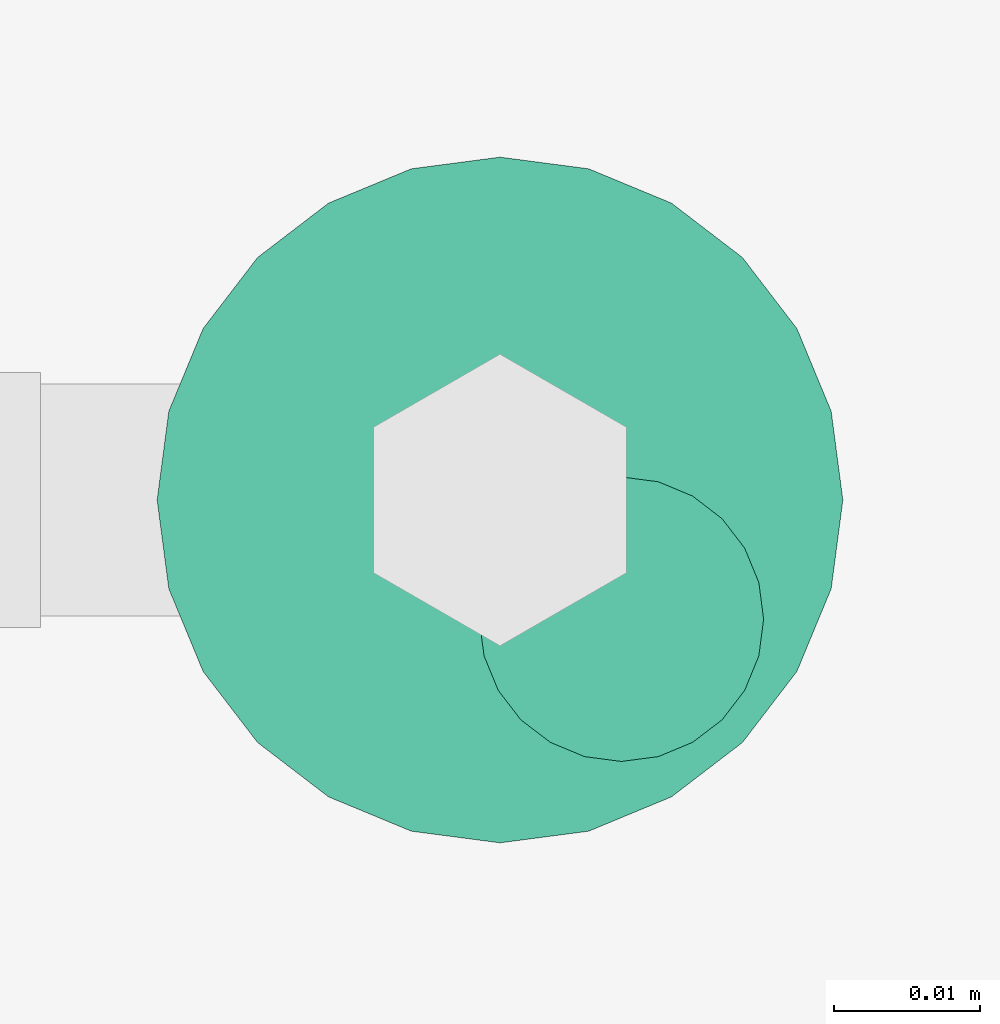
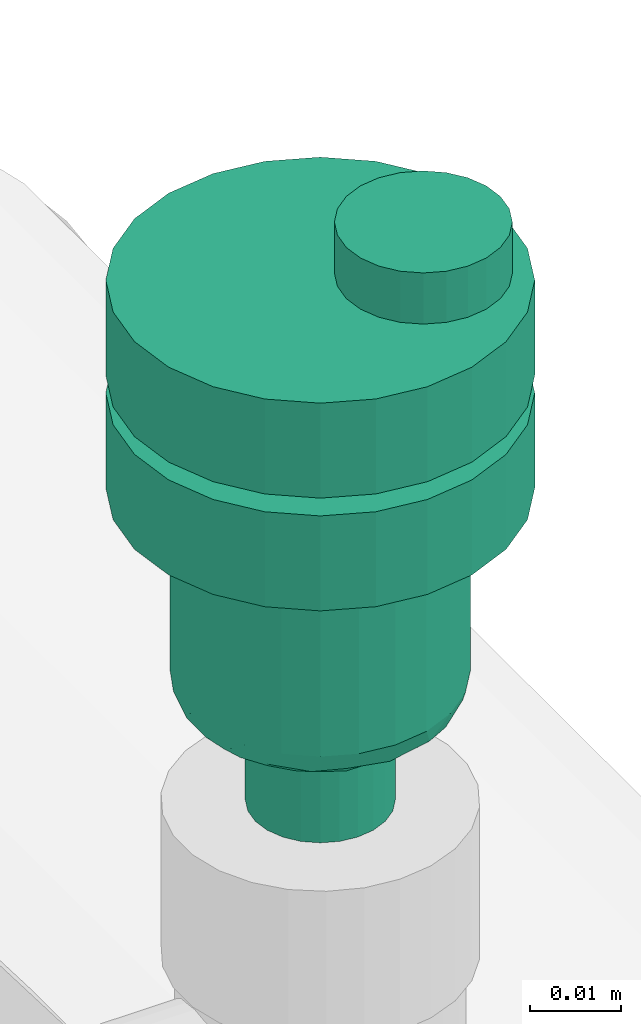
# One storey, part 596 of 827: 1 flow controller.
"""IFC2X3 building model written with IfcOpenShell, lengths in millimetres."""

from ifc_helpers import new_model, entity, si_unit, converted_unit, derived_unit, direction, frame, origin, place, context, subcontext, project, spatial, faceted_brep, source, transform, mapped, material, type_object, type_shapes, element, save


model = new_model("IFC2X3")

# Units and contexts
model_context = context("Model", 3, precision=0.01, world=origin(), true_north=direction((6.12303176911189e-17, 1.0)))
body_context = subcontext(model_context, "Body", "Model", "MODEL_VIEW")
ifc_project = project(units=[si_unit("LENGTHUNIT", "METRE", prefix="MILLI"), si_unit("AREAUNIT", "SQUARE_METRE"), si_unit("VOLUMEUNIT", "CUBIC_METRE"), converted_unit("PLANEANGLEUNIT", "DEGREE", entity("IfcRatioMeasure", 0.0174532925199433), si_unit("PLANEANGLEUNIT", "RADIAN"), dimensions=[0, 0, 0, 0, 0, 0, 0]), si_unit("MASSUNIT", "GRAM", prefix="KILO"), derived_unit("MASSDENSITYUNIT", [(si_unit("MASSUNIT", "GRAM", prefix="KILO"), 1), (si_unit("LENGTHUNIT", "METRE"), -3)]), derived_unit("MOMENTOFINERTIAUNIT", [(si_unit("LENGTHUNIT", "METRE"), 4)]), si_unit("TIMEUNIT", "SECOND"), si_unit("FREQUENCYUNIT", "HERTZ"), si_unit("THERMODYNAMICTEMPERATUREUNIT", "DEGREE_CELSIUS"), derived_unit("THERMALTRANSMITTANCEUNIT", [(si_unit("MASSUNIT", "GRAM", prefix="KILO"), 1), (si_unit("THERMODYNAMICTEMPERATUREUNIT", "KELVIN"), -1), (si_unit("TIMEUNIT", "SECOND"), -3)]), derived_unit("VOLUMETRICFLOWRATEUNIT", [(si_unit("LENGTHUNIT", "METRE"), 3), (si_unit("TIMEUNIT", "SECOND"), -1)]), derived_unit("MASSFLOWRATEUNIT", [(si_unit("MASSUNIT", "GRAM", prefix="KILO"), 1), (si_unit("TIMEUNIT", "SECOND"), -1)]), derived_unit("ROTATIONALFREQUENCYUNIT", [(si_unit("TIMEUNIT", "SECOND"), -1)]), si_unit("ELECTRICCURRENTUNIT", "AMPERE"), si_unit("ELECTRICVOLTAGEUNIT", "VOLT"), si_unit("POWERUNIT", "WATT"), si_unit("FORCEUNIT", "NEWTON", prefix="KILO"), si_unit("ILLUMINANCEUNIT", "LUX"), si_unit("LUMINOUSFLUXUNIT", "LUMEN"), si_unit("LUMINOUSINTENSITYUNIT", "CANDELA"), derived_unit("USERDEFINED", [(si_unit("MASSUNIT", "GRAM", prefix="KILO"), -1), (si_unit("LENGTHUNIT", "METRE"), -2), (si_unit("TIMEUNIT", "SECOND"), 3), (si_unit("LUMINOUSFLUXUNIT", "LUMEN"), 1)]), derived_unit("LINEARVELOCITYUNIT", [(si_unit("LENGTHUNIT", "METRE"), 1), (si_unit("TIMEUNIT", "SECOND"), -1)]), si_unit("PRESSUREUNIT", "PASCAL"), derived_unit("USERDEFINED", [(si_unit("LENGTHUNIT", "METRE"), -2), (si_unit("MASSUNIT", "GRAM", prefix="KILO"), 1), (si_unit("TIMEUNIT", "SECOND"), -2)]), derived_unit("LINEARFORCEUNIT", [(si_unit("MASSUNIT", "GRAM", prefix="KILO"), 1), (si_unit("LENGTHUNIT", "METRE"), 1), (si_unit("TIMEUNIT", "SECOND"), -2), (si_unit("LENGTHUNIT", "METRE"), -1)]), derived_unit("PLANARFORCEUNIT", [(si_unit("MASSUNIT", "GRAM", prefix="KILO"), 1), (si_unit("LENGTHUNIT", "METRE"), 1), (si_unit("TIMEUNIT", "SECOND"), -2), (si_unit("LENGTHUNIT", "METRE"), -2)])], contexts=[model_context])

# Site, building, storey
site_placement = place(None, origin())
site = spatial("IfcSite", under=ifc_project, at=site_placement, CompositionType="ELEMENT")
building_placement = place(site_placement, origin())
building = spatial("IfcBuilding", under=site, at=building_placement, CompositionType="ELEMENT")
storey_placement = place(building_placement, frame((0.0, 0.0, 28200.0)))
storey = spatial("IfcBuildingStorey", under=building, at=storey_placement, Name="08", CompositionType="ELEMENT", Elevation=28200.0)

# Flow controller
ifc_material = material()
valve_type = type_object("IfcValveType", PredefinedType="NOTDEFINED", material=ifc_material)
shared_shape = source(origin(), body_context, "Body", "Brep", [
    faceted_brep([(-6.86, -13.27, -15.58), (-5.66, -12.77, -15.58), (-5.66, -12.77, -13.2), (-6.86, -13.27, -13.2), (-6.86, -13.27, -0.5), (-5.66, -12.77, -0.5), (-5.66, -12.77, 2.49), (-6.86, -13.27, 2.49), (-8.16, -13.44, -15.58), (-8.16, -13.44, -13.2), (-8.16, -13.44, -0.5), (-8.16, -13.44, 2.49), (-3.83, -10.94, -15.58), (-3.33, -9.74, -15.58), (-3.33, -9.74, -13.2), (-3.83, -10.94, -13.2), (-3.83, -10.94, -0.5), (-3.33, -9.74, -0.5), (-3.33, -9.74, 2.49), (-3.83, -10.94, 2.49), (-4.62, -11.98, -15.58), (-4.62, -11.98, -13.2), (-4.62, -11.98, -0.5), (-4.62, -11.98, 2.49), (-3.16, -8.44, -13.2), (-3.16, -8.44, -15.58), (-3.16, -8.44, 2.49), (-3.16, -8.44, -0.5), (-3.83, -5.94, -15.58), (-4.62, -4.91, -15.58), (-4.62, -4.91, -13.2), (-3.83, -5.94, -13.2), (-3.83, -5.94, -0.5), (-4.62, -4.91, -0.5), (-4.62, -4.91, 2.49), (-3.83, -5.94, 2.49), (-3.33, -7.15, -15.58), (-3.33, -7.15, -13.2), (-3.33, -7.15, -0.5), (-3.33, -7.15, 2.49), (-6.86, -3.61, -15.58), (-8.16, -3.44, -15.58), (-8.16, -3.44, -13.2), (-6.86, -3.61, -13.2), (-6.86, -3.61, -0.5), (-8.16, -3.44, -0.5), (-8.16, -3.44, 2.49), (-6.86, -3.61, 2.49), (-5.66, -4.11, -15.58), (-5.66, -4.11, -13.2), (-5.66, -4.11, -0.5), (-5.66, -4.11, 2.49), (-9.45, -3.61, -0.5), (-9.45, -3.61, 2.49), (-9.45, -3.61, -15.58), (-9.45, -3.61, -13.2), (-10.66, -4.11, -0.5), (-10.66, -4.11, 2.49), (-10.66, -4.11, -15.58), (-10.66, -4.11, -13.2), (-12.49, -5.94, 2.49), (-11.69, -4.91, 2.49), (-11.69, -4.91, -0.5), (-12.49, -5.94, -0.5), (-11.69, -4.91, -15.58), (-12.49, -5.94, -15.58), (-12.49, -5.94, -13.2), (-11.69, -4.91, -13.2), (-12.99, -7.15, 2.49), (-12.99, -7.15, -0.5), (-12.99, -7.15, -15.58), (-12.99, -7.15, -13.2), (-13.16, -8.44, 2.49), (-13.16, -8.44, -0.5), (-13.16, -8.44, -13.2), (-13.16, -8.44, -15.58), (-12.49, -10.94, -0.5), (-12.49, -10.94, 2.49), (-12.99, -9.74, 2.49), (-12.99, -9.74, -0.5), (-12.99, -9.74, -15.58), (-12.49, -10.94, -15.58), (-12.49, -10.94, -13.2), (-12.99, -9.74, -13.2), (-11.69, -11.98, -0.5), (-11.69, -11.98, 2.49), (-11.69, -11.98, -15.58), (-11.69, -11.98, -13.2), (-9.45, -13.27, 2.49), (-10.66, -12.77, 2.49), (-10.66, -12.77, -0.5), (-9.45, -13.27, -0.5), (-10.66, -12.77, -15.58), (-9.45, -13.27, -15.58), (-9.45, -13.27, -13.2), (-10.66, -12.77, -13.2), (6.08, -22.7, -0.5), (0.0, -23.5, -0.5), (11.75, -20.35, -0.5), (16.62, -16.62, -0.5), (20.35, -11.75, -0.5), (22.7, -6.08, -0.5), (23.5, 0.0, -0.5), (22.7, 6.08, -0.5), (20.35, 11.75, -0.5), (16.62, 16.62, -0.5), (11.75, 20.35, -0.5), (6.08, 22.7, -0.5), (0.0, 23.5, -0.5), (-6.08, 22.7, -0.5), (-11.75, 20.35, -0.5), (-16.62, 16.62, -0.5), (-20.35, 11.75, -0.5), (-22.7, 6.08, -0.5), (-23.5, 0.0, -0.5), (-22.7, -6.08, -0.5), (-20.35, -11.75, -0.5), (-16.62, -16.62, -0.5), (-11.75, -20.35, -0.5), (-6.08, -22.7, -0.5), (11.75, 20.35, -13.2), (6.08, 22.7, -13.2), (16.62, 16.62, -13.2), (20.35, 11.75, -13.2), (22.7, 6.08, -13.2), (23.5, 0.0, -13.2), (22.7, -6.08, -13.2), (20.35, -11.75, -13.2), (16.62, -16.62, -13.2), (11.75, -20.35, -13.2), (6.08, -22.7, -13.2), (0.0, -23.5, -13.2), (-6.08, -22.7, -13.2), (-11.75, -20.35, -13.2), (-16.62, -16.62, -13.2), (-20.35, -11.75, -13.2), (-22.7, -6.08, -13.2), (-23.5, 0.0, -13.2), (-22.7, 6.08, -13.2), (-20.35, 11.75, -13.2), (-16.62, 16.62, -13.2), (-11.75, 20.35, -13.2), (-6.08, 22.7, -13.2), (0.0, 23.5, -13.2), (-22.7, -6.08, -28.28), (-22.7, -6.08, -15.58), (-23.5, 0.0, -15.58), (-23.5, 0.0, -28.28), (-20.35, -11.75, -28.28), (-20.35, -11.75, -15.58), (-11.75, -20.35, -15.58), (-16.62, -16.62, -15.58), (-16.62, -16.62, -28.28), (-11.75, -20.35, -28.28), (-6.08, -22.7, -15.58), (-6.08, -22.7, -28.28), (0.0, -23.5, -15.58), (0.0, -23.5, -28.28), (6.08, -22.7, -28.28), (6.08, -22.7, -15.58), (11.75, -20.35, -28.28), (11.75, -20.35, -15.58), (20.35, -11.75, -15.58), (16.62, -16.62, -15.58), (16.62, -16.62, -28.28), (20.35, -11.75, -28.28), (22.7, -6.08, -15.58), (22.7, -6.08, -28.28), (23.5, 0.0, -15.58), (23.5, 0.0, -28.28), (22.7, 6.08, -28.28), (22.7, 6.08, -15.58), (20.35, 11.75, -28.28), (20.35, 11.75, -15.58), (11.75, 20.35, -15.58), (16.62, 16.62, -15.58), (16.62, 16.62, -28.28), (11.75, 20.35, -28.28), (6.08, 22.7, -15.58), (6.08, 22.7, -28.28), (0.0, 23.5, -15.58), (0.0, 23.5, -28.28), (-6.08, 22.7, -28.28), (-6.08, 22.7, -15.58), (-11.75, 20.35, -28.28), (-11.75, 20.35, -15.58), (-20.35, 11.75, -15.58), (-16.62, 16.62, -15.58), (-16.62, 16.62, -28.28), (-20.35, 11.75, -28.28), (-22.7, 6.08, -15.58), (-22.7, 6.08, -28.28), (8.23, 14.25, -28.28), (4.26, 15.89, -28.28), (11.63, 11.63, -28.28), (14.25, 8.22, -28.28), (15.89, 4.26, -28.28), (16.45, 0.0, -28.28), (15.89, -4.26, -28.28), (14.25, -8.23, -28.28), (11.63, -11.63, -28.28), (8.23, -14.25, -28.28), (4.26, -15.89, -28.28), (0.0, -16.45, -28.28), (-4.26, -15.89, -28.28), (-8.22, -14.25, -28.28), (-11.63, -11.63, -28.28), (-14.25, -8.23, -28.28), (-15.89, -4.26, -28.28), (-16.45, 0.0, -28.28), (-15.89, 4.26, -28.28), (-14.25, 8.22, -28.28), (-11.63, 11.63, -28.28), (-8.22, 14.25, -28.28), (-4.26, 15.89, -28.28), (0.0, 16.45, -28.28), (-15.89, -4.26, -52.7), (-16.45, 0.0, -52.7), (-14.25, -8.23, -52.7), (-11.63, -11.63, -52.7), (-8.22, -14.25, -52.7), (-4.26, -15.89, -52.7), (0.0, -16.45, -52.7), (4.26, -15.89, -52.7), (8.23, -14.25, -52.7), (11.63, -11.63, -52.7), (14.25, -8.23, -52.7), (15.89, -4.26, -52.7), (16.45, 0.0, -52.7), (15.89, 4.26, -52.7), (14.25, 8.22, -52.7), (11.63, 11.63, -52.7), (8.23, 14.25, -52.7), (4.26, 15.89, -52.7), (0.0, 16.45, -52.7), (-4.26, 15.89, -52.7), (-8.22, 14.25, -52.7), (-11.63, 11.63, -52.7), (-14.25, 8.22, -52.7), (-15.89, 4.26, -52.7), (10.61, 9.36, -56.39), (8.29, 11.45, -56.39), (9.98, 12.23, -54.94), (-13.58, 4.48, -56.31), (-14.89, 5.25, -54.94), (-12.77, 8.5, -55.51), (6.32, 14.92, -54.11), (-3.39, 14.2, -56.13), (-6.26, 13.77, -55.71), (-2.15, 15.69, -54.85), (2.15, 15.59, -55.0), (10.54, 4.37, -56.8), (12.15, 6.9, -56.46), (14.89, 5.25, -54.94), (13.8, 0.0, -56.2), (13.58, 4.48, -56.31), (12.77, 8.5, -55.51), (15.25, 0.0, -55.6), (-9.98, 12.23, -54.94), (6.26, 13.77, -55.71), (4.37, 10.54, -56.8), (3.28, 13.85, -56.34), (-15.25, 0.0, -55.6), (-6.32, 14.92, -54.11), (-10.54, 4.37, -56.8), (-12.35, 0.0, -56.8), (-12.15, 6.9, -56.46), (-10.61, 9.36, -56.39), (8.73, 8.73, -56.8), (-4.37, 10.54, -56.8), (-6.55, 9.64, -56.8), (-13.8, 0.0, -56.2), (-0.21, 14.49, -56.2), (0.0, 12.35, -56.8), (-8.73, 8.73, -56.8), (-8.29, 11.45, -56.39), (12.35, 0.0, -56.8), (-10.61, -9.36, -56.39), (-8.29, -11.45, -56.39), (-9.98, -12.23, -54.94), (13.58, -4.48, -56.31), (14.89, -5.25, -54.94), (12.77, -8.5, -55.51), (-6.32, -14.92, -54.11), (6.32, -14.92, -54.11), (9.98, -12.23, -54.94), (-2.15, -15.59, -55.0), (-10.54, -4.37, -56.8), (-12.15, -6.9, -56.46), (-12.77, -8.5, -55.51), (2.15, -15.69, -54.85), (-14.89, -5.25, -54.94), (-13.58, -4.48, -56.31), (-8.73, -8.73, -56.8), (6.26, -13.77, -55.71), (4.37, -10.54, -56.8), (6.55, -9.64, -56.8), (12.15, -6.9, -56.46), (10.61, -9.36, -56.39), (10.54, -4.37, -56.8), (-6.26, -13.77, -55.71), (-4.37, -10.54, -56.8), (-3.28, -13.85, -56.34), (3.39, -14.2, -56.13), (0.21, -14.49, -56.2), (0.0, -12.35, -56.8), (8.73, -8.73, -56.8), (8.29, -11.45, -56.39), (-7.94, 2.13, -56.8), (-8.22, 0.0, -56.8), (-7.12, 4.11, -56.8), (-7.94, -2.13, -56.8), (-7.12, -4.11, -56.8), (-5.82, -5.82, -56.8), (-4.11, -7.12, -56.8), (-2.13, -7.94, -56.8), (0.0, -8.23, -56.8), (2.13, -7.94, -56.8), (4.11, -7.12, -56.8), (5.82, -5.82, -56.8), (7.12, -4.11, -56.8), (7.94, -2.13, -56.8), (8.23, 0.0, -56.8), (7.94, 2.13, -56.8), (7.12, 4.11, -56.8), (5.82, 5.82, -56.8), (4.11, 7.12, -56.8), (2.13, 7.94, -56.8), (0.0, 8.22, -56.8), (-2.13, 7.94, -56.8), (-4.11, 7.12, -56.8), (-5.82, 5.82, -56.8), (0.0, 8.22, -70.0), (2.13, 7.94, -70.0), (4.11, 7.12, -70.0), (5.82, 5.82, -70.0), (7.12, 4.11, -70.0), (7.94, 2.13, -70.0), (8.23, 0.0, -70.0), (7.94, -2.13, -70.0), (7.12, -4.11, -70.0), (5.82, -5.82, -70.0), (4.11, -7.12, -70.0), (2.13, -7.94, -70.0), (0.0, -8.23, -70.0), (-2.13, -7.94, -70.0), (-4.11, -7.12, -70.0), (-5.82, -5.82, -70.0), (-7.12, -4.11, -70.0), (-7.94, -2.13, -70.0), (-8.22, 0.0, -70.0), (-7.94, 2.13, -70.0), (-7.12, 4.11, -70.0), (-5.82, 5.82, -70.0), (-4.11, 7.12, -70.0), (-2.13, 7.94, -70.0), (1.25, -5.8, 9.33), (0.27, -3.45, 9.33), (-1.28, -1.43, 9.33), (-3.3, 0.12, 9.33), (-5.65, 1.09, 9.33), (-8.17, 1.43, 9.33), (-10.69, 1.09, 9.33), (-13.05, 0.12, 9.33), (-15.07, -1.43, 9.33), (-16.61, -3.45, 9.33), (-17.59, -5.8, 9.33), (-17.92, -8.32, 9.33), (-17.59, -10.85, 9.33), (-16.61, -13.2, 9.33), (-15.07, -15.22, 9.33), (-13.05, -16.77, 9.33), (-10.69, -17.74, 9.33), (-8.17, -18.07, 9.33), (-5.65, -17.74, 9.33), (-3.3, -16.77, 9.33), (-1.28, -15.22, 9.33), (0.27, -13.2, 9.33), (1.25, -10.85, 9.33), (1.58, -8.32, 9.33), (-16.61, -3.45, 2.49), (-17.59, -5.8, 2.49), (-15.07, -1.43, 2.49), (-13.05, 0.12, 2.49), (-10.69, 1.09, 2.49), (-8.17, 1.43, 2.49), (-5.65, 1.09, 2.49), (-3.3, 0.12, 2.49), (-1.28, -1.43, 2.49), (0.27, -3.45, 2.49), (1.25, -5.8, 2.49), (1.58, -8.32, 2.49), (1.25, -10.85, 2.49), (0.27, -13.2, 2.49), (-1.28, -15.22, 2.49), (-3.3, -16.77, 2.49), (-5.65, -17.74, 2.49), (-8.17, -18.07, 2.49), (-10.69, -17.74, 2.49), (-13.05, -16.77, 2.49), (-15.07, -15.22, 2.49), (-16.61, -13.2, 2.49), (-17.59, -10.85, 2.49), (-17.92, -8.32, 2.49)], [[[0, 1, 2, 3]], [[4, 5, 6, 7]], [[8, 0, 3, 9]], [[10, 4, 7, 11]], [[12, 13, 14, 15]], [[16, 17, 18, 19]], [[20, 12, 15, 21]], [[22, 16, 19, 23]], [[1, 20, 21, 2]], [[5, 22, 23, 6]], [[24, 14, 13, 25]], [[26, 18, 17, 27]], [[28, 29, 30, 31]], [[32, 33, 34, 35]], [[36, 28, 31, 37]], [[38, 32, 35, 39]], [[40, 41, 42, 43]], [[44, 45, 46, 47]], [[48, 40, 43, 49]], [[50, 44, 47, 51]], [[29, 48, 49, 30]], [[33, 50, 51, 34]], [[36, 37, 24, 25]], [[38, 39, 26, 27]], [[52, 53, 46, 45]], [[41, 54, 55, 42]], [[56, 57, 53, 52]], [[54, 58, 59, 55]], [[60, 61, 62, 63]], [[64, 65, 66, 67]], [[56, 62, 61, 57]], [[58, 64, 67, 59]], [[68, 60, 63, 69]], [[65, 70, 71, 66]], [[72, 68, 69, 73]], [[74, 71, 70, 75]], [[76, 77, 78, 79]], [[80, 81, 82, 83]], [[84, 85, 77, 76]], [[81, 86, 87, 82]], [[88, 89, 90, 91]], [[92, 93, 94, 95]], [[84, 90, 89, 85]], [[86, 92, 95, 87]], [[11, 88, 91, 10]], [[93, 8, 9, 94]], [[79, 78, 72, 73]], [[80, 83, 74, 75]], [[96, 16, 97]], [[16, 96, 17]], [[98, 17, 96]], [[27, 17, 98]], [[98, 99, 27]], [[100, 27, 99]], [[100, 38, 27]], [[38, 100, 101]], [[38, 101, 102]], [[38, 102, 32]], [[32, 102, 103]], [[104, 32, 103]], [[104, 33, 32]], [[104, 105, 33]], [[105, 106, 33]], [[106, 50, 33]], [[50, 106, 107]], [[50, 107, 108]], [[108, 44, 50]], [[44, 108, 109]], [[44, 109, 110]], [[110, 45, 44]], [[45, 110, 111]], [[45, 111, 112]], [[52, 45, 112]], [[52, 112, 113]], [[56, 52, 113]], [[113, 114, 56]], [[114, 62, 56]], [[62, 114, 63]], [[114, 115, 63]], [[115, 69, 63]], [[73, 69, 115]], [[115, 116, 73]], [[116, 79, 73]], [[79, 116, 76]], [[76, 116, 117]], [[76, 117, 84]], [[117, 90, 84]], [[118, 90, 117]], [[90, 118, 91]], [[10, 91, 118]], [[10, 118, 119]], [[97, 5, 119]], [[119, 5, 4]], [[10, 119, 4]], [[22, 97, 16]], [[22, 5, 97]], [[120, 49, 121]], [[49, 120, 30]], [[122, 30, 120]], [[122, 123, 30]], [[30, 123, 31]], [[123, 124, 31]], [[31, 124, 125]], [[37, 31, 125]], [[37, 125, 126]], [[127, 37, 126]], [[37, 127, 24]], [[127, 128, 24]], [[129, 24, 128]], [[14, 24, 129]], [[129, 130, 14]], [[130, 15, 14]], [[130, 131, 15]], [[131, 21, 15]], [[2, 21, 131]], [[2, 131, 132]], [[2, 132, 3]], [[3, 132, 9]], [[132, 133, 9]], [[94, 9, 133]], [[133, 95, 94]], [[95, 133, 134]], [[95, 134, 87]], [[82, 87, 134]], [[135, 82, 134]], [[135, 83, 82]], [[74, 83, 135]], [[135, 136, 74]], [[74, 136, 71]], [[71, 136, 66]], [[66, 136, 137]], [[137, 67, 66]], [[67, 137, 59]], [[137, 138, 59]], [[59, 138, 55]], [[139, 55, 138]], [[55, 139, 42]], [[140, 42, 139]], [[141, 42, 140]], [[42, 141, 43]], [[141, 142, 43]], [[43, 142, 143]], [[121, 49, 143]], [[43, 143, 49]], [[136, 115, 114, 137]], [[144, 145, 146, 147]], [[135, 116, 115, 136]], [[148, 149, 145, 144]], [[118, 117, 134, 133]], [[150, 151, 152, 153]], [[135, 134, 117, 116]], [[148, 152, 151, 149]], [[119, 118, 133, 132]], [[154, 150, 153, 155]], [[97, 119, 132, 131]], [[156, 154, 155, 157]], [[130, 96, 97, 131]], [[158, 159, 156, 157]], [[129, 98, 96, 130]], [[160, 161, 159, 158]], [[100, 99, 128, 127]], [[162, 163, 164, 165]], [[129, 128, 99, 98]], [[160, 164, 163, 161]], [[101, 100, 127, 126]], [[166, 162, 165, 167]], [[102, 101, 126, 125]], [[168, 166, 167, 169]], [[124, 103, 102, 125]], [[170, 171, 168, 169]], [[123, 104, 103, 124]], [[172, 173, 171, 170]], [[106, 105, 122, 120]], [[174, 175, 176, 177]], [[123, 122, 105, 104]], [[172, 176, 175, 173]], [[107, 106, 120, 121]], [[178, 174, 177, 179]], [[108, 107, 121, 143]], [[180, 178, 179, 181]], [[142, 109, 108, 143]], [[182, 183, 180, 181]], [[141, 110, 109, 142]], [[184, 185, 183, 182]], [[112, 111, 140, 139]], [[186, 187, 188, 189]], [[141, 140, 111, 110]], [[184, 188, 187, 185]], [[113, 112, 139, 138]], [[190, 186, 189, 191]], [[114, 113, 138, 137]], [[146, 190, 191, 147]], [[159, 12, 156]], [[12, 159, 13]], [[161, 13, 159]], [[25, 13, 161]], [[161, 163, 25]], [[162, 25, 163]], [[162, 36, 25]], [[36, 162, 166]], [[36, 166, 168]], [[36, 168, 28]], [[28, 168, 171]], [[173, 28, 171]], [[173, 29, 28]], [[173, 175, 29]], [[175, 174, 29]], [[174, 48, 29]], [[48, 174, 178]], [[48, 178, 180]], [[180, 40, 48]], [[40, 180, 183]], [[40, 183, 185]], [[185, 41, 40]], [[41, 185, 187]], [[41, 187, 186]], [[54, 41, 186]], [[54, 186, 190]], [[58, 54, 190]], [[190, 146, 58]], [[146, 64, 58]], [[64, 146, 65]], [[146, 145, 65]], [[145, 70, 65]], [[75, 70, 145]], [[145, 149, 75]], [[149, 80, 75]], [[80, 149, 81]], [[81, 149, 151]], [[81, 151, 86]], [[151, 92, 86]], [[150, 92, 151]], [[92, 150, 93]], [[8, 93, 150]], [[8, 150, 154]], [[156, 1, 154]], [[154, 1, 0]], [[8, 154, 0]], [[20, 156, 12]], [[20, 1, 156]], [[177, 176, 192]], [[177, 192, 193]], [[193, 179, 177]], [[192, 176, 194]], [[172, 194, 176]], [[195, 194, 172]], [[196, 195, 172]], [[196, 172, 170]], [[196, 170, 197]], [[197, 170, 169]], [[198, 197, 169]], [[198, 169, 167]], [[199, 198, 167]], [[199, 167, 165]], [[200, 199, 165]], [[165, 164, 200]], [[164, 201, 200]], [[201, 164, 160]], [[201, 160, 202]], [[158, 202, 160]], [[202, 158, 203]], [[203, 158, 157]], [[157, 204, 203]], [[204, 157, 155]], [[204, 155, 205]], [[153, 205, 155]], [[153, 206, 205]], [[153, 152, 206]], [[207, 206, 152]], [[148, 207, 152]], [[144, 207, 148]], [[208, 207, 144]], [[208, 144, 147]], [[147, 209, 208]], [[191, 209, 147]], [[191, 210, 209]], [[210, 191, 189]], [[211, 210, 189]], [[211, 189, 188]], [[211, 188, 212]], [[188, 184, 212]], [[212, 184, 213]], [[213, 184, 182]], [[182, 214, 213]], [[181, 214, 182]], [[179, 215, 181]], [[214, 181, 215]], [[179, 193, 215]], [[216, 208, 209, 217]], [[218, 207, 208, 216]], [[205, 206, 219, 220]], [[218, 219, 206, 207]], [[204, 205, 220, 221]], [[221, 222, 203, 204]], [[202, 223, 224, 201]], [[225, 200, 201, 224]], [[199, 226, 227, 198]], [[225, 226, 199, 200]], [[198, 227, 228, 197]], [[223, 202, 203, 222]], [[229, 196, 197, 228]], [[230, 195, 196, 229]], [[192, 194, 231, 232]], [[230, 231, 194, 195]], [[193, 192, 232, 233]], [[193, 233, 234, 215]], [[214, 235, 236, 213]], [[237, 212, 213, 236]], [[211, 238, 239, 210]], [[237, 238, 211, 212]], [[210, 239, 217, 209]], [[235, 214, 215, 234]], [[240, 241, 242]], [[243, 244, 245]], [[246, 233, 232]], [[247, 248, 249]], [[233, 246, 250]], [[251, 240, 252]], [[253, 254, 255]], [[231, 256, 242]], [[229, 257, 253]], [[228, 257, 229]], [[230, 253, 256]], [[253, 255, 256]], [[229, 253, 230]], [[236, 258, 237]], [[242, 232, 231]], [[259, 260, 261]], [[249, 234, 250]], [[262, 239, 244]], [[230, 256, 231]], [[235, 263, 236]], [[244, 239, 238]], [[243, 264, 265]], [[263, 258, 236]], [[241, 260, 259]], [[234, 249, 235]], [[245, 244, 238]], [[233, 250, 234]], [[258, 245, 237]], [[266, 267, 264]], [[238, 237, 245]], [[240, 251, 268]], [[248, 269, 270]], [[262, 217, 239]], [[243, 271, 244]], [[246, 242, 259]], [[258, 267, 245]], [[240, 256, 252]], [[240, 242, 256]], [[247, 249, 272]], [[263, 249, 248]], [[273, 272, 261]], [[272, 249, 250]], [[274, 267, 275]], [[270, 274, 275]], [[241, 240, 268]], [[275, 258, 248]], [[264, 267, 274]], [[261, 272, 250]], [[247, 273, 269]], [[259, 261, 250]], [[273, 261, 260]], [[273, 247, 272]], [[269, 248, 247]], [[266, 245, 267]], [[251, 255, 276]], [[254, 253, 257]], [[254, 276, 255]], [[271, 262, 244]], [[243, 265, 271]], [[260, 241, 268]], [[242, 241, 259]], [[258, 275, 267]], [[270, 275, 248]], [[242, 246, 232]], [[250, 246, 259]], [[249, 263, 235]], [[258, 263, 248]], [[256, 255, 252]], [[255, 251, 252]], [[264, 243, 266]], [[243, 245, 266]], [[277, 278, 279]], [[280, 281, 282]], [[283, 221, 220]], [[284, 285, 224]], [[221, 283, 286]], [[287, 277, 288]], [[277, 289, 288]], [[219, 289, 279]], [[290, 222, 286]], [[217, 262, 216]], [[218, 291, 289]], [[291, 292, 289]], [[277, 287, 293]], [[216, 291, 218]], [[279, 220, 219]], [[294, 295, 296]], [[224, 285, 225]], [[257, 227, 281]], [[297, 298, 299]], [[226, 281, 227]], [[226, 225, 282]], [[291, 271, 292]], [[227, 257, 228]], [[226, 282, 281]], [[277, 279, 289]], [[218, 289, 219]], [[300, 301, 302]], [[290, 223, 222]], [[280, 254, 281]], [[223, 284, 224]], [[285, 282, 225]], [[221, 286, 222]], [[278, 301, 300]], [[303, 294, 290]], [[216, 262, 291]], [[285, 298, 282]], [[283, 279, 300]], [[280, 299, 276]], [[303, 290, 304]], [[284, 290, 294]], [[305, 304, 302]], [[304, 290, 286]], [[306, 298, 307]], [[296, 306, 307]], [[278, 277, 293]], [[307, 285, 294]], [[299, 298, 306]], [[302, 304, 286]], [[303, 305, 295]], [[300, 302, 286]], [[305, 302, 301]], [[305, 303, 304]], [[295, 294, 303]], [[297, 282, 298]], [[287, 292, 265]], [[271, 291, 262]], [[271, 265, 292]], [[254, 257, 281]], [[280, 276, 254]], [[301, 278, 293]], [[279, 278, 300]], [[285, 307, 298]], [[296, 307, 294]], [[279, 283, 220]], [[286, 283, 300]], [[290, 284, 223]], [[285, 284, 294]], [[289, 292, 288]], [[292, 287, 288]], [[299, 280, 297]], [[280, 282, 297]], [[308, 309, 265]], [[308, 265, 264]], [[308, 264, 274]], [[310, 308, 274]], [[311, 265, 309]], [[311, 287, 265]], [[311, 293, 287]], [[312, 293, 311]], [[312, 313, 293]], [[313, 314, 293]], [[314, 301, 293]], [[314, 305, 301]], [[305, 314, 315]], [[315, 316, 305]], [[316, 317, 305]], [[318, 305, 317]], [[318, 295, 305]], [[318, 296, 295]], [[318, 306, 296]], [[319, 306, 318]], [[320, 306, 319]], [[306, 320, 321]], [[321, 299, 306]], [[321, 276, 299]], [[322, 276, 321]], [[323, 276, 322]], [[323, 251, 276]], [[323, 268, 251]], [[323, 324, 268]], [[324, 325, 268]], [[268, 325, 326]], [[326, 260, 268]], [[326, 273, 260]], [[326, 327, 273]], [[328, 273, 327]], [[328, 329, 273]], [[329, 330, 273]], [[330, 331, 274]], [[330, 274, 270]], [[330, 270, 269]], [[330, 269, 273]], [[310, 274, 331]], [[332, 333, 334, 335, 336, 337, 338, 339, 340, 341, 342, 343, 344, 345, 346, 347, 348, 349, 350, 351, 352, 353, 354, 355]], [[349, 311, 309, 350]], [[348, 312, 311, 349]], [[314, 313, 347, 346]], [[348, 347, 313, 312]], [[315, 314, 346, 345]], [[316, 315, 345, 344]], [[343, 317, 316, 344]], [[342, 318, 317, 343]], [[320, 319, 341, 340]], [[342, 341, 319, 318]], [[321, 320, 340, 339]], [[322, 321, 339, 338]], [[337, 323, 322, 338]], [[336, 324, 323, 337]], [[326, 325, 335, 334]], [[336, 335, 325, 324]], [[327, 326, 334, 333]], [[328, 327, 333, 332]], [[355, 329, 328, 332]], [[354, 330, 329, 355]], [[310, 331, 353, 352]], [[354, 353, 331, 330]], [[308, 310, 352, 351]], [[309, 308, 351, 350]], [[356, 357, 358, 359, 360, 361, 362, 363, 364, 365, 366, 367, 368, 369, 370, 371, 372, 373, 374, 375, 376, 377, 378, 379]], [[380, 60, 381]], [[60, 380, 61]], [[382, 61, 380]], [[61, 382, 57]], [[382, 383, 57]], [[53, 57, 383]], [[384, 53, 383]], [[53, 384, 46]], [[46, 384, 385]], [[386, 46, 385]], [[46, 386, 47]], [[386, 387, 47]], [[51, 47, 387]], [[388, 51, 387]], [[388, 34, 51]], [[388, 389, 34]], [[389, 35, 34]], [[389, 390, 35]], [[39, 35, 390]], [[39, 390, 391]], [[39, 391, 26]], [[392, 26, 391]], [[18, 26, 392]], [[18, 392, 393]], [[19, 18, 393]], [[19, 393, 394]], [[23, 19, 394]], [[394, 395, 23]], [[395, 6, 23]], [[396, 6, 395]], [[396, 7, 6]], [[7, 396, 397]], [[7, 397, 11]], [[11, 397, 88]], [[398, 88, 397]], [[88, 398, 89]], [[89, 398, 399]], [[89, 399, 85]], [[399, 400, 85]], [[85, 400, 77]], [[401, 77, 400]], [[77, 401, 78]], [[402, 78, 401]], [[402, 72, 78]], [[72, 402, 403]], [[403, 381, 68]], [[403, 68, 72]], [[60, 68, 381]], [[396, 374, 373, 397]], [[395, 375, 374, 396]], [[377, 376, 394, 393]], [[395, 394, 376, 375]], [[378, 377, 393, 392]], [[379, 378, 392, 391]], [[390, 356, 379, 391]], [[389, 357, 356, 390]], [[359, 358, 388, 387]], [[389, 388, 358, 357]], [[360, 359, 387, 386]], [[361, 360, 386, 385]], [[384, 362, 361, 385]], [[383, 363, 362, 384]], [[365, 364, 382, 380]], [[383, 382, 364, 363]], [[366, 365, 380, 381]], [[367, 366, 381, 403]], [[402, 368, 367, 403]], [[401, 369, 368, 402]], [[371, 370, 400, 399]], [[401, 400, 370, 369]], [[372, 371, 399, 398]], [[373, 372, 398, 397]]]),
])
type_shapes(valve_type, [shared_shape])
flow_controller_placement = place(storey_placement, frame((31430.0, 10420.0, 2790.5), z_axis=(0.0, 0.0, 1.0), x_axis=(0.0, 1.0, 0.0)))
element("IfcFlowController", 1, at=flow_controller_placement, inside=storey, type_object=valve_type, material=ifc_material, context=body_context, shape_type="MappedRepresentation", body=[
    mapped(shared_shape, transform((0.0, 0.0, 0.0), scale=1.0)),
])

save(model, "model.ifc")
